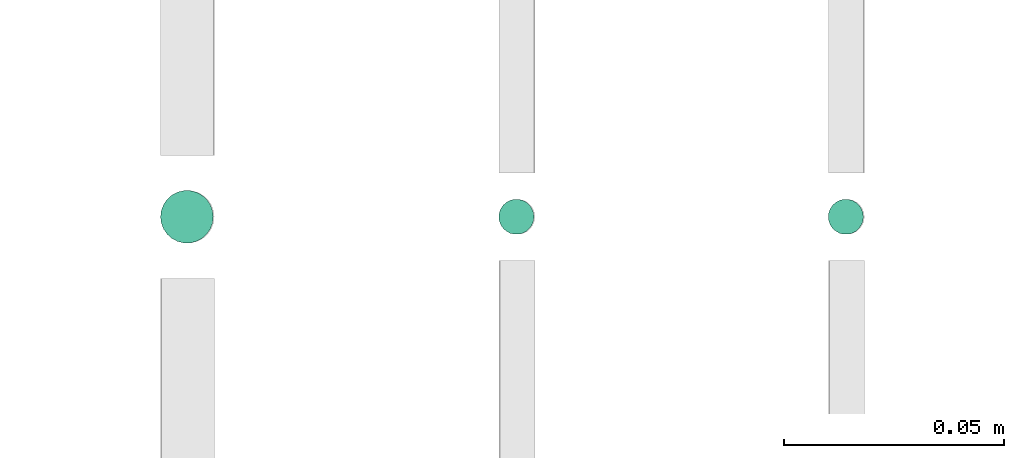
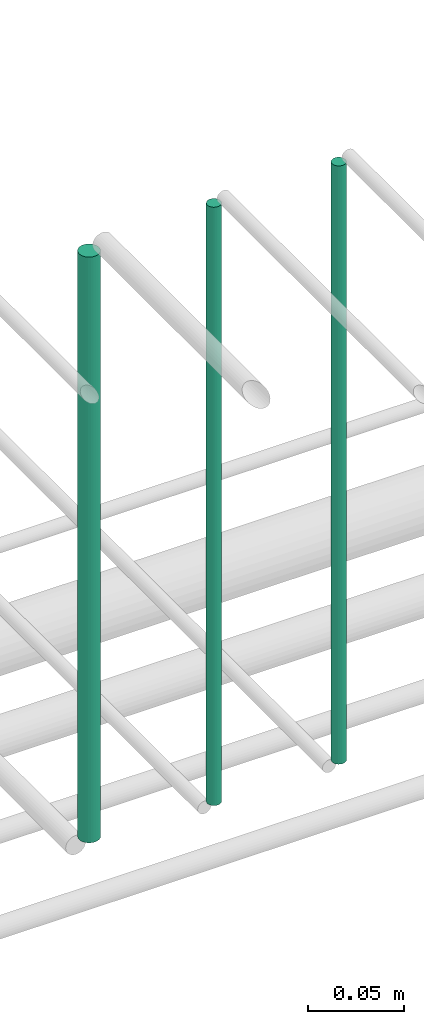
# One storey, part 148 of 331: 3 flow segments.
"""IFC2X3 building model written with IfcOpenShell, lengths in millimetres."""

from ifc_helpers import new_model, entity, si_unit, converted_unit, derived_unit, direction, frame, frame_2d, origin, origin_2d_with_axis, place, context, subcontext, project, spatial, circle, extrude, type_object, element, save


model = new_model("IFC2X3")

# Units and contexts
model_context = context("Model", 3, precision=0.01, world=origin(), true_north=direction((6.12303176911189e-17, 1.0)))
body_context = subcontext(model_context, "Body", "Model", "MODEL_VIEW")
ifc_project = project(units=[si_unit("LENGTHUNIT", "METRE", prefix="MILLI"), si_unit("AREAUNIT", "SQUARE_METRE"), si_unit("VOLUMEUNIT", "CUBIC_METRE"), converted_unit("PLANEANGLEUNIT", "DEGREE", entity("IfcRatioMeasure", 0.0174532925199433), si_unit("PLANEANGLEUNIT", "RADIAN"), dimensions=[0, 0, 0, 0, 0, 0, 0]), si_unit("MASSUNIT", "GRAM", prefix="KILO"), derived_unit("MASSDENSITYUNIT", [(si_unit("MASSUNIT", "GRAM", prefix="KILO"), 1), (si_unit("LENGTHUNIT", "METRE"), -3)]), derived_unit("MOMENTOFINERTIAUNIT", [(si_unit("LENGTHUNIT", "METRE"), 4)]), si_unit("TIMEUNIT", "SECOND"), si_unit("FREQUENCYUNIT", "HERTZ"), si_unit("THERMODYNAMICTEMPERATUREUNIT", "DEGREE_CELSIUS"), derived_unit("THERMALTRANSMITTANCEUNIT", [(si_unit("MASSUNIT", "GRAM", prefix="KILO"), 1), (si_unit("THERMODYNAMICTEMPERATUREUNIT", "KELVIN"), -1), (si_unit("TIMEUNIT", "SECOND"), -3)]), derived_unit("VOLUMETRICFLOWRATEUNIT", [(si_unit("LENGTHUNIT", "METRE"), 3), (si_unit("TIMEUNIT", "SECOND"), -1)]), derived_unit("MASSFLOWRATEUNIT", [(si_unit("MASSUNIT", "GRAM", prefix="KILO"), 1), (si_unit("TIMEUNIT", "SECOND"), -1)]), derived_unit("ROTATIONALFREQUENCYUNIT", [(si_unit("TIMEUNIT", "SECOND"), -1)]), si_unit("ELECTRICCURRENTUNIT", "AMPERE"), si_unit("ELECTRICVOLTAGEUNIT", "VOLT"), si_unit("POWERUNIT", "WATT"), si_unit("FORCEUNIT", "NEWTON", prefix="KILO"), si_unit("ILLUMINANCEUNIT", "LUX"), si_unit("LUMINOUSFLUXUNIT", "LUMEN"), si_unit("LUMINOUSINTENSITYUNIT", "CANDELA"), derived_unit("USERDEFINED", [(si_unit("MASSUNIT", "GRAM", prefix="KILO"), -1), (si_unit("LENGTHUNIT", "METRE"), -2), (si_unit("TIMEUNIT", "SECOND"), 3), (si_unit("LUMINOUSFLUXUNIT", "LUMEN"), 1)]), derived_unit("LINEARVELOCITYUNIT", [(si_unit("LENGTHUNIT", "METRE"), 1), (si_unit("TIMEUNIT", "SECOND"), -1)]), si_unit("PRESSUREUNIT", "PASCAL"), derived_unit("USERDEFINED", [(si_unit("LENGTHUNIT", "METRE"), -2), (si_unit("MASSUNIT", "GRAM", prefix="KILO"), 1), (si_unit("TIMEUNIT", "SECOND"), -2)]), derived_unit("LINEARFORCEUNIT", [(si_unit("MASSUNIT", "GRAM", prefix="KILO"), 1), (si_unit("LENGTHUNIT", "METRE"), 1), (si_unit("TIMEUNIT", "SECOND"), -2), (si_unit("LENGTHUNIT", "METRE"), -1)]), derived_unit("PLANARFORCEUNIT", [(si_unit("MASSUNIT", "GRAM", prefix="KILO"), 1), (si_unit("LENGTHUNIT", "METRE"), 1), (si_unit("TIMEUNIT", "SECOND"), -2), (si_unit("LENGTHUNIT", "METRE"), -2)])], contexts=[model_context])

# Site, building, storey
site_placement = place(None, frame((0.0, -0.00077364408347762, 0.0)))
site = spatial("IfcSite", under=ifc_project, at=site_placement, CompositionType="ELEMENT")
building_placement = place(site_placement, origin())
building = spatial("IfcBuilding", under=site, at=building_placement, CompositionType="ELEMENT")
storey_placement = place(building_placement, origin())
storey = spatial("IfcBuildingStorey", under=building, at=storey_placement, CompositionType="ELEMENT", Elevation=0.0)

# Flow segments
pipe_segment_type = type_object("IfcPipeSegmentType", PredefinedType="NOTDEFINED")
flow_segment_1_placement = place(storey_placement, frame((35765.5130615671, 5638.02529159149, 14760.0)))
element("IfcFlowSegment", 1, at=flow_segment_1_placement, inside=storey, type_object=pipe_segment_type, context=body_context, shape_type="SweptSolid", body=[
    extrude(circle(Radius=4.0, at=frame_2d((0.0, -1.08286712929839e-12), x_axis=(1.0, 0.0))), frame((5.59527223591499, 5.59527223591499, 0.0), z_axis=(0.0, 0.0, 1.0), x_axis=(-1.0, 0.0, 0.0)), (0.0, 0.0, 1.0), 379.999999999979),
])
flow_segment_2_placement = place(storey_placement, frame((35690.5130615671, 5638.02529159149, 14760.0)))
element("IfcFlowSegment", 2, at=flow_segment_2_placement, inside=storey, type_object=pipe_segment_type, context=body_context, shape_type="SweptSolid", body=[
    extrude(circle(Radius=4.0, at=origin_2d_with_axis()), frame((5.59527223591499, 5.59527223591607, 0.0), z_axis=(0.0, 0.0, 1.0), x_axis=(-1.0, 0.0, 0.0)), (0.0, 0.0, 1.0), 379.999999999987),
])
flow_segment_3_placement = place(storey_placement, frame((35613.5130615671, 5636.02529159149, 14764.0)))
element("IfcFlowSegment", 3, at=flow_segment_3_placement, inside=storey, type_object=pipe_segment_type, context=body_context, shape_type="SweptSolid", body=[
    extrude(circle(Radius=6.0, at=frame_2d((0.0, -1.08286712929839e-12), x_axis=(1.0, 0.0))), frame((7.59527223591454, 7.59527223591454, 0.0), z_axis=(0.0, 0.0, 1.0), x_axis=(-1.0, 0.0, 0.0)), (0.0, 0.0, 1.0), 371.999999999978),
])

save(model, "model.ifc")
